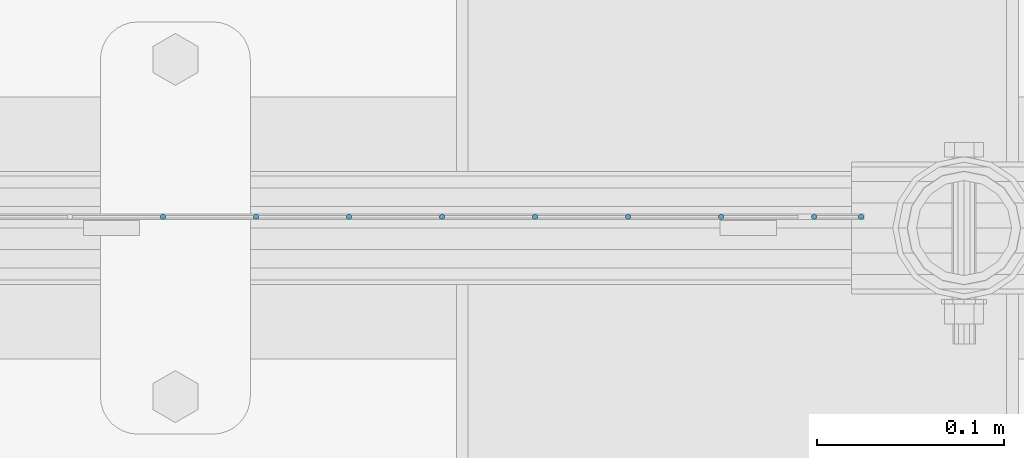
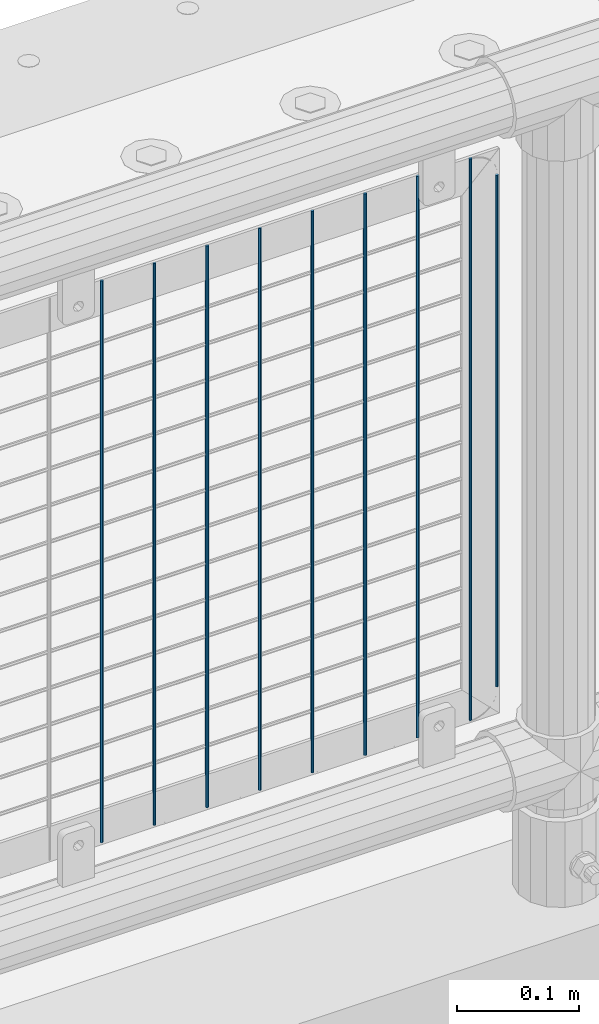
# One storey, part 82 of 208: 9 columns.
"""IFC2X3 building model written with IfcOpenShell, lengths in millimetres."""

from ifc_helpers import new_model, si_unit, frame, origin_with_axes, place, context, subcontext, project, spatial, faceted_brep, material, type_object, element, save


model = new_model("IFC2X3")

# Units and contexts
model_context = context("Model", 3, precision=1e-05, world=origin_with_axes())
body_context = subcontext(model_context, "Body", "Model", "MODEL_VIEW")
ifc_project = project(units=[si_unit("LENGTHUNIT", "METRE", prefix="MILLI"), si_unit("AREAUNIT", "SQUARE_METRE"), si_unit("VOLUMEUNIT", "CUBIC_METRE"), si_unit("MASSUNIT", "GRAM", prefix="KILO"), si_unit("TIMEUNIT", "SECOND"), si_unit("PLANEANGLEUNIT", "RADIAN"), si_unit("SOLIDANGLEUNIT", "STERADIAN"), si_unit("THERMODYNAMICTEMPERATUREUNIT", "DEGREE_CELSIUS"), si_unit("LUMINOUSINTENSITYUNIT", "LUMEN")], contexts=[model_context])

# Site, building, storey
site_placement = place(None, origin_with_axes())
site = spatial("IfcSite", under=ifc_project, at=site_placement, CompositionType="ELEMENT")
building_placement = place(site_placement, origin_with_axes())
building = spatial("IfcBuilding", under=site, at=building_placement, Name="Standard", CompositionType="ELEMENT")
storey_placement = place(building_placement, origin_with_axes())
storey = spatial("IfcBuildingStorey", under=building, at=storey_placement, Name="Undefined", CompositionType="ELEMENT", Elevation=0.0)

# Columns
ifc_material = material(Name="Misc_Undefined")
column_type = type_object("IfcColumnType", Name="D3", PredefinedType="NOTDEFINED")
for number, where, z_axis, x_axis in (
    (1, (-29109.005, 4670.50000000001, 353.020000000005), (-1.0, 0.0, 0.0), (0.0, 0.0, 1.0)),
    (2, (-29158.66, 4670.50000000001, 353.020000000005), (-1.0, 0.0, 0.0), (0.0, 0.0, 1.0)),
    (3, (-29208.315, 4670.50000000001, 353.020000000005), (-1.0, 0.0, 0.0), (0.0, 0.0, 1.0)),
    (4, (-29257.97, 4670.50000000001, 353.020000000005), (-1.0, 0.0, 0.0), (0.0, 0.0, 1.0)),
    (5, (-29307.625, 4670.50000000001, 353.020000000005), (-1.0, 0.0, 0.0), (0.0, 0.0, 1.0)),
    (6, (-29357.28, 4670.50000000001, 353.020000000005), (-1.0, 0.0, 0.0), (0.0, 0.0, 1.0)),
    (7, (-29406.935, 4670.50000000001, 353.020000000005), (-1.0, 0.0, 0.0), (0.0, 0.0, 1.0)),
    (8, (-29456.59, 4670.50000000001, 353.020000000005), (-1.0, 0.0, 0.0), (0.0, 0.0, 1.0)),
):
    element("IfcColumn", number, at=place(storey_placement, frame(where, z_axis=z_axis, x_axis=x_axis)), inside=storey, type_object=column_type, material=ifc_material, ObjectType="D3", context=body_context, shape_type="Brep", body=[
        faceted_brep([(0.0, -1.49999999999909, 3.63797880709171e-12), (-7.27595761418343e-12, -0.749999999999091, -1.29903810567669), (560.0, -0.75, -1.29903810567703), (560.0, -1.5, 0.0), (-3.63797880709171e-12, 0.750000000000909, -1.29903810567669), (560.0, 0.75, -1.29903810567703), (0.0, 1.50000000000182, 3.63797880709171e-12), (560.0, 1.5, 0.0), (-3.63797880709171e-12, 0.750000000000909, 1.29903810567669), (560.0, 0.75, 1.29903810567703), (-7.27595761418343e-12, -0.749999999999091, 1.29903810567669), (560.0, -0.75, 1.29903810567703)], [[[0, 1, 2, 3]], [[1, 4, 5, 2]], [[4, 6, 7, 5]], [[6, 8, 9, 7]], [[8, 10, 11, 9]], [[10, 0, 3, 11]], [[5, 7, 9, 11, 3, 2]], [[10, 8, 6, 4, 1, 0]]]),
    ])
column_placement = place(storey_placement, frame((-29084.0, 4670.50000000001, 378.020000000005), z_axis=(-1.0, 0.0, 0.0), x_axis=(0.0, 0.0, 1.0)))
element("IfcColumn", 9, at=column_placement, inside=storey, type_object=column_type, material=ifc_material, ObjectType="D3", context=body_context, shape_type="Brep", body=[
    faceted_brep([(0.0, -1.49999999999909, 3.63797880709171e-12), (-7.27595761418343e-12, -0.749999999999091, -1.29903810567669), (510.0, -0.75, -1.29903810567703), (510.0, -1.5, 0.0), (-3.63797880709171e-12, 0.750000000000909, -1.29903810567669), (510.0, 0.75, -1.29903810567703), (0.0, 1.50000000000182, 3.63797880709171e-12), (510.0, 1.5, 0.0), (-3.63797880709171e-12, 0.750000000000909, 1.29903810567669), (510.0, 0.75, 1.29903810567703), (-7.27595761418343e-12, -0.749999999999091, 1.29903810567669), (510.0, -0.75, 1.29903810567703)], [[[0, 1, 2, 3]], [[1, 4, 5, 2]], [[4, 6, 7, 5]], [[6, 8, 9, 7]], [[8, 10, 11, 9]], [[10, 0, 3, 11]], [[5, 7, 9, 11, 3, 2]], [[10, 8, 6, 4, 1, 0]]]),
])

save(model, "model.ifc")
